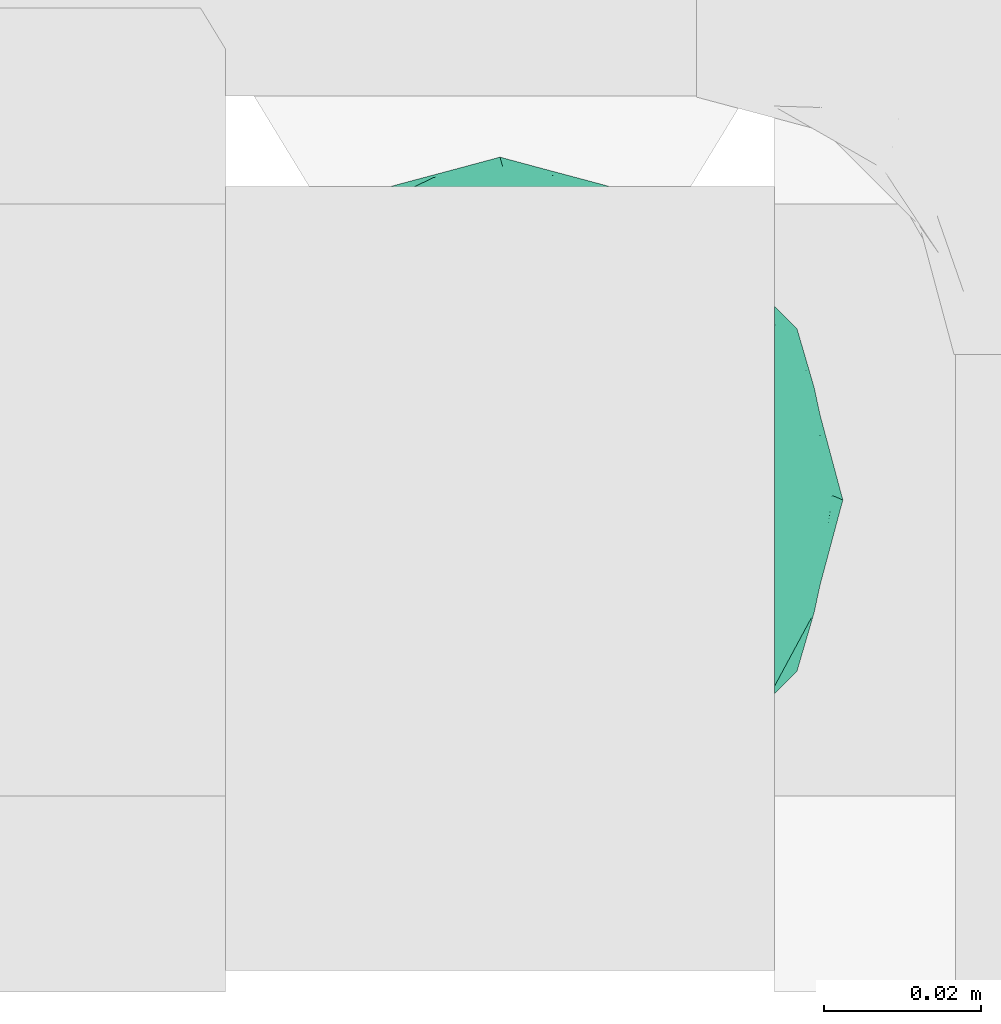
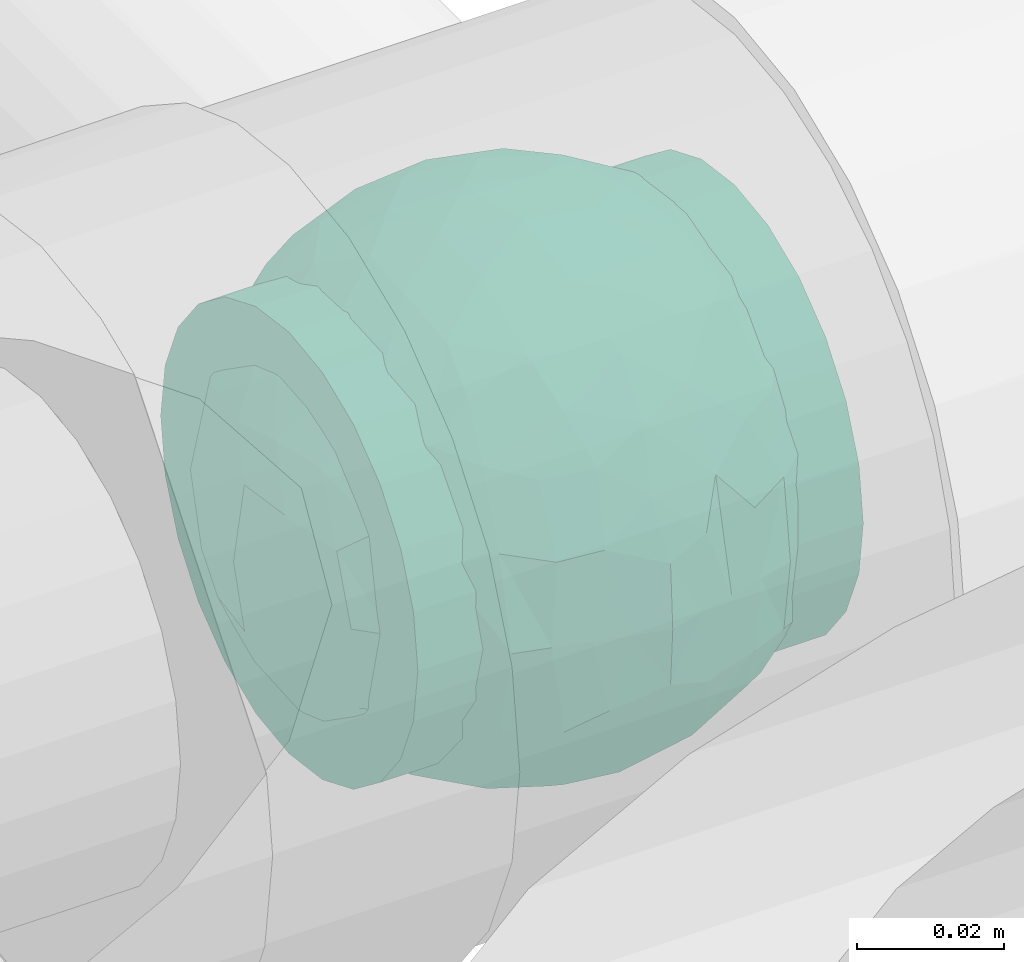
# One storey, part 692 of 827: 1 flow fitting.
"""IFC2X3 building model written with IfcOpenShell, lengths in millimetres."""

import ifcopenshell
import ifcopenshell.guid

model = None  # the IFC model being written
_history = None  # IfcOwnerHistory: only IFC2X3 demands one
_inside = {}  # id of a spatial element -> (the spatial element, [elements in it])
_under = {}  # id of a project, library or spatial element -> (it, [spatial elements below it])
_declared = {}  # id of a project -> (the project, [libraries it declares])
_typed = {}  # id of a type object -> (the type object, [elements of that type])
_made_of = {}  # id of a material, layer set ... -> (it, [elements and type objects made of it])


def new_model(schema):
    """Start an empty IFC model of exactly this schema.

    Asked for "IFC4X3", IfcOpenShell would pick the latest addendum, in which some entities
    have other attributes; the version numbers below select the first issue.
    IFC2X3 requires an IfcOwnerHistory on every rooted entity: one is made here for all.
    """
    global model, _history
    if schema == "IFC4X3":
        model = ifcopenshell.file(schema_version=(4, 3, 0, 0))
    else:
        model = ifcopenshell.file(schema=schema)
    _inside.clear()
    _under.clear()
    _declared.clear()
    _typed.clear()
    _made_of.clear()
    _history = None
    if model.schema == "IFC2X3":
        org = make("IfcOrganization", Name="unknown")
        user = make(
            "IfcPersonAndOrganization",
            ThePerson=make("IfcPerson", FamilyName="unknown"),
            TheOrganization=org,
        )
        app = make(
            "IfcApplication",
            ApplicationDeveloper=org,
            Version="unknown",
            ApplicationFullName="unknown",
            ApplicationIdentifier="unknown",
        )
        _history = make(
            "IfcOwnerHistory",
            OwningUser=user,
            OwningApplication=app,
            ChangeAction="ADDED",
            CreationDate=0,
        )
    return model


def make(cls, **values):
    """One entity of the class cls with the attributes given. An attribute that is None is left unset."""
    return model.create_entity(
        cls, **{name: value for name, value in values.items() if value is not None}
    )


def entity(cls, *values):
    """Any entity or typed value of the class cls, its attributes in the order of the schema. None: left unset."""
    e = model.create_entity(cls)
    for i, value in enumerate(values):
        if value is not None:
            e[i] = value
    return e


def rooted(cls, **values):
    """An entity with a GlobalId (a new one), such as an element, a storey or a relation."""
    return make(cls, GlobalId=ifcopenshell.guid.new(), OwnerHistory=_history, **values)


def si_unit(unit_type, name, prefix=None):
    """IfcSIUnit, for example si_unit("LENGTHUNIT", "METRE", prefix="MILLI")."""
    return make("IfcSIUnit", UnitType=unit_type, Prefix=prefix, Name=name)


def converted_unit(unit_type, name, factor, base, dimensions=None, offset=None):
    """IfcConversionBasedUnit, such as the inch: factor (a typed value) times the base unit."""
    return make(
        "IfcConversionBasedUnit"
        if offset is None
        else "IfcConversionBasedUnitWithOffset",
        ConversionOffset=offset,
        Dimensions=None
        if dimensions is None
        else entity("IfcDimensionalExponents", *dimensions),
        UnitType=unit_type,
        Name=name,
        ConversionFactor=make(
            "IfcMeasureWithUnit", ValueComponent=factor, UnitComponent=base
        ),
    )


def derived_unit(unit_type, elements):
    """IfcDerivedUnit: a product of units, each with its exponent."""
    return make(
        "IfcDerivedUnit",
        Elements=[
            make("IfcDerivedUnitElement", Unit=unit, Exponent=power)
            for unit, power in elements
        ],
        UnitType=unit_type,
    )


def assignment(units):
    """IfcUnitAssignment: the units of a project."""
    return None if units is None else make("IfcUnitAssignment", Units=units)


def point(xyz):
    """IfcCartesianPoint."""
    return None if xyz is None else make("IfcCartesianPoint", Coordinates=xyz)


def direction(xyz):
    """IfcDirection."""
    return None if xyz is None else make("IfcDirection", DirectionRatios=xyz)


def frame(location, z_axis=None, x_axis=None):
    """IfcAxis2Placement3D, a coordinate frame: its origin and axes. An axis left out is left unset."""
    return make(
        "IfcAxis2Placement3D",
        Location=point(location),
        Axis=direction(z_axis),
        RefDirection=direction(x_axis),
    )


def origin():
    """The frame at (0, 0, 0) with its axes left unset."""
    return frame((0.0, 0.0, 0.0))


def place(relative_to, where):
    """IfcLocalPlacement: puts the frame where relative to a parent placement (None: the world)."""
    return make(
        "IfcLocalPlacement", PlacementRelTo=relative_to, RelativePlacement=where
    )


def context(
    kind, dimensions, precision=None, world=None, true_north=None, identifier=None
):
    """IfcGeometricRepresentationContext, for example the 3D "Model" context."""
    return make(
        "IfcGeometricRepresentationContext",
        ContextIdentifier=identifier,
        ContextType=kind,
        CoordinateSpaceDimension=dimensions,
        Precision=precision,
        WorldCoordinateSystem=world,
        TrueNorth=true_north,
    )


def subcontext(parent, identifier, kind, view, scale=None):
    """IfcGeometricRepresentationSubContext, for example "Body" below "Model"."""
    return make(
        "IfcGeometricRepresentationSubContext",
        ContextIdentifier=identifier,
        ContextType=kind,
        ParentContext=parent,
        TargetScale=scale,
        TargetView=view,
    )


def project(units=None, contexts=None):
    """IfcProject with its units and contexts."""
    return rooted(
        "IfcProject",
        Name="project",
        RepresentationContexts=contexts,
        UnitsInContext=assignment(units),
    )


def spatial(cls, under=None, at=None, **own):
    """A site, building, storey or space (cls), placed at a placement, below another one or the project."""
    s = rooted(cls, ObjectPlacement=at, **own)
    if under is not None:
        _under.setdefault(under.id(), (under, []))[1].append(s)
    return s


def faces_of(points, faces, orient=None, outer=None):
    """IfcFace entities. A face is a list of loops; a loop is a list of indices into points, from 0.

    orient and outer hold one flag for each loop. By default every Orientation is true, the
    first loop of a face is its IfcFaceOuterBound and the others are IfcFaceBound.
    """
    made = []
    for i, loops in enumerate(faces):
        bounds = []
        for j, loop in enumerate(loops):
            is_outer = j == 0 if outer is None else outer[i][j]
            bounds.append(
                make(
                    "IfcFaceOuterBound" if is_outer else "IfcFaceBound",
                    Bound=make("IfcPolyLoop", Polygon=[points[k] for k in loop]),
                    Orientation=True if orient is None else orient[i][j],
                )
            )
        made.append(make("IfcFace", Bounds=bounds))
    return made


def faceted_brep(points, faces, orient=None, outer=None, voids=None):
    """IfcFacetedBrep: a solid bounded by flat faces; with voids (closed shells), ...WithVoids."""
    shared = [point(p) for p in points]
    hull = make("IfcClosedShell", CfsFaces=faces_of(shared, faces, orient, outer))
    if voids is None:
        return make("IfcFacetedBrep", Outer=hull)
    return make(
        "IfcFacetedBrepWithVoids",
        Outer=hull,
        Voids=[
            make(cls, CfsFaces=faces_of(shared, fs, o, b)) for cls, fs, o, b in voids
        ],
    )


def shape(context_of_items, identifier, shape_type, items):
    """IfcShapeRepresentation: the items that make up one representation, for example the "Body"."""
    return make(
        "IfcShapeRepresentation",
        ContextOfItems=context_of_items,
        RepresentationIdentifier=identifier,
        RepresentationType=shape_type,
        Items=items,
    )


def source(mapping_origin, context_of_items, identifier, shape_type, items):
    """IfcRepresentationMap: a shape defined once, which mapped items show again and again."""
    return make(
        "IfcRepresentationMap",
        MappingOrigin=mapping_origin,
        MappedRepresentation=shape(context_of_items, identifier, shape_type, items),
    )


def transform(
    local_origin,
    x_axis=None,
    y_axis=None,
    z_axis=None,
    scale=None,
    scale2=None,
    scale3=None,
    uniform=True,
):
    """IfcCartesianTransformationOperator3D, or its non-uniform kind. x_axis, y_axis, z_axis: its Axis1, 2, 3."""
    if uniform:
        return make(
            "IfcCartesianTransformationOperator3D",
            Axis1=direction(x_axis),
            Axis2=direction(y_axis),
            LocalOrigin=point(local_origin),
            Scale=scale,
            Axis3=direction(z_axis),
        )
    return make(
        "IfcCartesianTransformationOperator3DnonUniform",
        Axis1=direction(x_axis),
        Axis2=direction(y_axis),
        LocalOrigin=point(local_origin),
        Scale=scale,
        Axis3=direction(z_axis),
        Scale2=scale2,
        Scale3=scale3,
    )


def mapped(mapping_source, mapping_target):
    """IfcMappedItem: shows the shape of a source again, moved by a transform."""
    return make(
        "IfcMappedItem", MappingSource=mapping_source, MappingTarget=mapping_target
    )


def material(Name=None, Category=None):
    """IfcMaterial."""
    return make("IfcMaterial", Name=Name, Category=Category)


def material_list(materials):
    """IfcMaterialList."""
    return make("IfcMaterialList", Materials=materials)


def made_of(thing, what):
    """Note that an element or type object is made of a material, layer set ...; save() writes the relation."""
    if what is not None:
        _made_of.setdefault(what.id(), (what, []))[1].append(thing)
    return thing


def type_object(cls, material=None, **own):
    """A type object (cls), such as IfcWallType, which elements share."""
    return made_of(rooted(cls, **own), material)


def type_shapes(of_type, sources):
    """Give a type object the sources (RepresentationMaps) that its elements show as mapped items."""
    of_type.RepresentationMaps = sources


def element(
    cls,
    number,
    at=None,
    inside=None,
    cuts=None,
    type_object=None,
    material=None,
    context=None,
    identifier="Body",
    shape_type=None,
    held_by="IfcProductDefinitionShape",
    body=None,
    shapes=None,
    **own,
):
    """One element of the class cls, such as IfcWall. Its Tag is "e" and its number.

    at: its placement. inside: the storey or other place that contains it. cuts: it is an
    opening in that element (IfcRelVoidsElement). A single representation is given by context,
    identifier, shape_type and body (its items); several are given by shapes. held_by: the class
    of the entity that holds the representations. save() writes the other relations.
    """
    e = rooted(cls, Tag="e%d" % number, ObjectPlacement=at, **own)
    if body is not None:
        shapes = [shape(context, identifier, shape_type, body)]
    if shapes is not None:
        e.Representation = make(held_by, Representations=shapes)
    if inside is not None:
        _inside.setdefault(inside.id(), (inside, []))[1].append(e)
    if cuts is not None:
        rooted(
            "IfcRelVoidsElement", RelatingBuildingElement=cuts, RelatedOpeningElement=e
        )
    if type_object is not None:
        _typed.setdefault(type_object.id(), (type_object, []))[1].append(e)
    return made_of(e, material)


def aggregate(whole, parts):
    """IfcRelAggregates: a whole, such as a stair, and the parts it consists of."""
    return rooted("IfcRelAggregates", RelatingObject=whole, RelatedObjects=parts)


def save(model, path):
    """Write the relations noted so far, then the file.

    IfcRelAggregates (storeys below a building ...), IfcRelContainedInSpatialStructure (elements
    in a storey), IfcRelDefinesByType, IfcRelAssociatesMaterial and IfcRelDeclares: one each for
    every whole, place, type object, material and project.
    """
    for whole, parts in _under.values():
        aggregate(whole, parts)
    for where, things in _inside.values():
        rooted(
            "IfcRelContainedInSpatialStructure",
            RelatedElements=things,
            RelatingStructure=where,
        )
    for kind, things in _typed.values():
        rooted("IfcRelDefinesByType", RelatedObjects=things, RelatingType=kind)
    for what, things in _made_of.values():
        rooted("IfcRelAssociatesMaterial", RelatedObjects=things, RelatingMaterial=what)
    for by, libraries in _declared.values():
        rooted("IfcRelDeclares", RelatingContext=by, RelatedDefinitions=libraries)
    model.write(path)


model = new_model("IFC2X3")

# Units and contexts
model_context = context("Model", 3, precision=0.01, world=origin(), true_north=direction((6.12303176911189e-17, 1.0)))
body_context = subcontext(model_context, "Body", "Model", "MODEL_VIEW")
ifc_project = project(units=[si_unit("LENGTHUNIT", "METRE", prefix="MILLI"), si_unit("AREAUNIT", "SQUARE_METRE"), si_unit("VOLUMEUNIT", "CUBIC_METRE"), converted_unit("PLANEANGLEUNIT", "DEGREE", entity("IfcRatioMeasure", 0.0174532925199433), si_unit("PLANEANGLEUNIT", "RADIAN"), dimensions=[0, 0, 0, 0, 0, 0, 0]), si_unit("MASSUNIT", "GRAM", prefix="KILO"), derived_unit("MASSDENSITYUNIT", [(si_unit("MASSUNIT", "GRAM", prefix="KILO"), 1), (si_unit("LENGTHUNIT", "METRE"), -3)]), derived_unit("MOMENTOFINERTIAUNIT", [(si_unit("LENGTHUNIT", "METRE"), 4)]), si_unit("TIMEUNIT", "SECOND"), si_unit("FREQUENCYUNIT", "HERTZ"), si_unit("THERMODYNAMICTEMPERATUREUNIT", "DEGREE_CELSIUS"), derived_unit("THERMALTRANSMITTANCEUNIT", [(si_unit("MASSUNIT", "GRAM", prefix="KILO"), 1), (si_unit("THERMODYNAMICTEMPERATUREUNIT", "KELVIN"), -1), (si_unit("TIMEUNIT", "SECOND"), -3)]), derived_unit("VOLUMETRICFLOWRATEUNIT", [(si_unit("LENGTHUNIT", "METRE"), 3), (si_unit("TIMEUNIT", "SECOND"), -1)]), derived_unit("MASSFLOWRATEUNIT", [(si_unit("MASSUNIT", "GRAM", prefix="KILO"), 1), (si_unit("TIMEUNIT", "SECOND"), -1)]), derived_unit("ROTATIONALFREQUENCYUNIT", [(si_unit("TIMEUNIT", "SECOND"), -1)]), si_unit("ELECTRICCURRENTUNIT", "AMPERE"), si_unit("ELECTRICVOLTAGEUNIT", "VOLT"), si_unit("POWERUNIT", "WATT"), si_unit("FORCEUNIT", "NEWTON", prefix="KILO"), si_unit("ILLUMINANCEUNIT", "LUX"), si_unit("LUMINOUSFLUXUNIT", "LUMEN"), si_unit("LUMINOUSINTENSITYUNIT", "CANDELA"), derived_unit("USERDEFINED", [(si_unit("MASSUNIT", "GRAM", prefix="KILO"), -1), (si_unit("LENGTHUNIT", "METRE"), -2), (si_unit("TIMEUNIT", "SECOND"), 3), (si_unit("LUMINOUSFLUXUNIT", "LUMEN"), 1)]), derived_unit("LINEARVELOCITYUNIT", [(si_unit("LENGTHUNIT", "METRE"), 1), (si_unit("TIMEUNIT", "SECOND"), -1)]), si_unit("PRESSUREUNIT", "PASCAL"), derived_unit("USERDEFINED", [(si_unit("LENGTHUNIT", "METRE"), -2), (si_unit("MASSUNIT", "GRAM", prefix="KILO"), 1), (si_unit("TIMEUNIT", "SECOND"), -2)]), derived_unit("LINEARFORCEUNIT", [(si_unit("MASSUNIT", "GRAM", prefix="KILO"), 1), (si_unit("LENGTHUNIT", "METRE"), 1), (si_unit("TIMEUNIT", "SECOND"), -2), (si_unit("LENGTHUNIT", "METRE"), -1)]), derived_unit("PLANARFORCEUNIT", [(si_unit("MASSUNIT", "GRAM", prefix="KILO"), 1), (si_unit("LENGTHUNIT", "METRE"), 1), (si_unit("TIMEUNIT", "SECOND"), -2), (si_unit("LENGTHUNIT", "METRE"), -2)])], contexts=[model_context])

# Site, building, storey
site_placement = place(None, origin())
site = spatial("IfcSite", under=ifc_project, at=site_placement, CompositionType="ELEMENT")
building_placement = place(site_placement, origin())
building = spatial("IfcBuilding", under=site, at=building_placement, CompositionType="ELEMENT")
storey_placement = place(building_placement, frame((0.0, 0.0, 28200.0)))
storey = spatial("IfcBuildingStorey", under=building, at=storey_placement, Name="08", CompositionType="ELEMENT", Elevation=28200.0)

# Flow fitting
ifc_material_1 = material()
ifc_material_2 = material(Name="ADSK_")
ifc_material_list = material_list([ifc_material_1, ifc_material_2])
pipe_fitting_type = type_object("IfcPipeFittingType", Name="ADSK_1", PredefinedType="NOTDEFINED", material=ifc_material_list)
shared_shape = source(origin(), body_context, "Body", "Brep", [
    faceted_brep([(-35.0, 9.06, -33.81), (-35.0, 0.0, -35.0), (-35.0, -9.06, -33.81), (-35.0, -17.5, -30.31), (-35.0, -24.75, -24.75), (-35.0, -30.31, -17.5), (-35.0, -33.81, -9.06), (-35.0, -34.4, -4.53), (-35.0, -35.0, 0.0), (-35.0, -34.4, 4.53), (-35.0, -33.81, 9.06), (-35.0, -30.31, 17.5), (-35.0, -24.75, 24.75), (-35.0, -17.5, 30.31), (-35.0, -9.06, 33.81), (-35.0, 0.0, 35.0), (-35.0, 9.06, 33.81), (-35.0, 17.5, 30.31), (-35.0, 24.75, 24.75), (-35.0, 30.31, 17.5), (-35.0, 33.81, 9.06), (-35.0, 35.0, 0.0), (-35.0, 33.81, -9.06), (-35.0, 30.31, -17.5), (-35.0, 24.75, -24.75), (-35.0, 17.5, -30.31), (35.0, 33.81, -9.06), (35.0, 35.0, 0.0), (35.0, 33.81, 9.06), (35.0, 30.31, 17.5), (35.0, 24.75, 24.75), (35.0, 17.5, 30.31), (35.0, 9.06, 33.81), (35.0, 0.0, 35.0), (35.0, -9.06, 33.81), (35.0, -17.5, 30.31), (35.0, -24.75, 24.75), (35.0, -30.31, 17.5), (35.0, -33.81, 9.06), (35.0, -34.4, 4.53), (35.0, -35.0, 0.0), (35.0, -34.4, -4.53), (35.0, -33.81, -9.06), (35.0, -30.31, -17.5), (35.0, -24.75, -24.75), (35.0, -17.5, -30.31), (35.0, -9.06, -33.81), (35.0, 0.0, -35.0), (35.0, 9.06, -33.81), (35.0, 17.5, -30.31), (35.0, 24.75, -24.75), (35.0, 30.31, -17.5), (12.5, -35.0, 0.0), (11.74, -34.73, 4.3), (9.57, -34.06, 8.04), (2.19, -32.76, 12.31), (6.27, -33.29, 10.81), (-9.57, -34.06, 8.04), (-11.74, -34.73, 4.3), (-12.5, -35.0, 0.0), (-6.27, -33.29, 10.81), (-2.19, -32.76, 12.31), (-11.74, -34.73, -4.3), (9.57, -34.06, -8.04), (11.74, -34.73, -4.3), (6.27, -33.29, -10.81), (2.19, -32.76, -12.31), (-2.19, -32.76, -12.31), (-6.27, -33.29, -10.81), (-9.57, -34.06, -8.04), (0.0, -40.0, -12.5), (3.24, -40.0, -12.07), (6.25, -40.0, -10.83), (8.84, -40.0, -8.84), (10.83, -40.0, -6.25), (12.07, -40.0, -3.24), (12.5, -40.0, 0.0), (12.07, -40.0, 3.24), (10.83, -40.0, 6.25), (8.84, -40.0, 8.84), (6.25, -40.0, 10.83), (3.24, -40.0, 12.07), (0.0, -40.0, 12.5), (-3.24, -40.0, 12.07), (-6.25, -40.0, 10.83), (-8.84, -40.0, 8.84), (-10.83, -40.0, 6.25), (-12.07, -40.0, 3.24), (-12.5, -40.0, 0.0), (-12.07, -40.0, -3.24), (-10.83, -40.0, -6.25), (-8.84, -40.0, -8.84), (-6.25, -40.0, -10.83), (-3.24, -40.0, -12.07)], [[[0, 1, 2, 3, 4, 5, 6, 7, 8, 9, 10, 11, 12, 13, 14, 15, 16, 17, 18, 19, 20, 21, 22, 23, 24, 25]], [[26, 27, 28, 29, 30, 31, 32, 33, 34, 35, 36, 37, 38, 39, 40, 41, 42, 43, 44, 45, 46, 47, 48, 49, 50, 51]], [[52, 40, 53]], [[54, 53, 39]], [[39, 38, 54]], [[55, 37, 11]], [[38, 55, 56]], [[55, 38, 37]], [[38, 56, 54]], [[37, 36, 12, 11]], [[57, 9, 58]], [[8, 58, 9]], [[8, 59, 58]], [[57, 10, 9]], [[60, 61, 10]], [[61, 11, 10]], [[61, 55, 11]], [[60, 10, 57]], [[53, 40, 39]], [[36, 35, 13, 12]], [[15, 14, 34, 33]], [[14, 13, 35, 34]], [[16, 15, 33, 32]], [[29, 28, 20, 19]], [[18, 17, 31, 30]], [[19, 18, 30, 29]], [[32, 31, 17, 16]], [[21, 20, 28, 27]], [[21, 27, 26, 22]], [[22, 26, 51, 23]], [[24, 23, 51, 50]], [[2, 1, 47, 46]], [[0, 25, 49, 48]], [[47, 1, 0, 48]], [[49, 25, 24, 50]], [[45, 3, 2, 46]], [[62, 8, 7]], [[45, 44, 4, 3]], [[5, 4, 44, 43]], [[63, 41, 64]], [[42, 65, 66]], [[66, 43, 42]], [[5, 43, 66]], [[41, 40, 64]], [[63, 42, 41]], [[52, 64, 40]], [[42, 63, 65]], [[5, 67, 6]], [[67, 68, 6]], [[5, 66, 67]], [[62, 7, 69]], [[7, 6, 69]], [[8, 62, 59]], [[69, 6, 68]], [[70, 71, 72, 73, 74, 75, 76, 77, 78, 79, 80, 81, 82, 83, 84, 85, 86, 87, 88, 89, 90, 91, 92, 93]], [[59, 88, 87]], [[58, 86, 85]], [[87, 86, 59]], [[85, 84, 58]], [[59, 86, 58]], [[57, 58, 83]], [[61, 60, 56]], [[57, 54, 60]], [[83, 82, 57]], [[84, 83, 58]], [[54, 82, 81]], [[80, 53, 81]], [[53, 79, 78]], [[80, 79, 53]], [[52, 78, 77]], [[56, 55, 61]], [[54, 56, 60]], [[78, 52, 53]], [[53, 54, 81]], [[52, 77, 76]], [[57, 82, 54]], [[76, 75, 52]], [[73, 72, 64]], [[74, 73, 64]], [[75, 74, 52]], [[52, 74, 64]], [[63, 64, 71]], [[66, 65, 67]], [[63, 68, 65]], [[71, 70, 63]], [[72, 71, 64]], [[93, 92, 62]], [[70, 93, 69]], [[90, 89, 59]], [[91, 90, 62]], [[92, 91, 62]], [[68, 67, 65]], [[69, 68, 63]], [[90, 59, 62]], [[62, 69, 93]], [[59, 89, 88]], [[63, 70, 69]]]),
    faceted_brep([(40.99, -9.07, -12.32), (38.16, -18.39, -10.93), (36.84, -12.08, -20.28), (-10.94, -40.82, 0.0), (-15.58, -39.11, -11.91), (-9.92, -38.23, -18.83), (-21.96, -6.8, -37.22), (-28.12, 0.0, -33.51), (-18.49, 2.46, -39.57), (7.18, -35.67, -24.29), (15.31, -38.73, -13.42), (8.77, -40.44, -14.19), (42.03, 0.03, -12.13), (40.09, 14.36, -10.04), (40.82, 10.94, 0.0), (23.53, 13.3, -34.4), (12.46, 12.13, -40.15), (17.01, 22.71, -33.3), (33.97, -22.81, -15.49), (33.89, -25.88, 0.0), (-17.56, -33.17, -22.48), (-9.73, -30.72, -29.59), (32.82, 10.98, -26.77), (35.78, 20.39, -14.77), (39.41, 6.34, -17.91), (-6.73, 41.38, -12.52), (-10.94, 40.82, 0.0), (-5.47, 42.28, 0.0), (-39.41, -6.34, -17.91), (-34.66, -3.23, -26.5), (-35.7, -17.2, -18.54), (-40.84, 8.27, -13.33), (-40.82, 10.94, 0.0), (-39.08, 16.52, -10.68), (26.2, -22.53, -26.83), (19.73, -22.3, -32.05), (18.8, -14.77, -36.64), (-40.09, -14.36, -10.04), (-42.42, 0.57, -10.68), (-38.6, 2.92, -20.39), (-33.71, 5.81, -27.28), (-35.11, 22.36, -13.46), (-36.84, 12.08, -20.28), (-7.82, 5.75, -42.66), (-4.31, 16.52, -40.28), (2.55, 8.59, -42.82), (-28.09, 28.94, -16.95), (-22.22, 29.25, -23.76), (-22.19, 21.47, -31.0), (-15.79, 13.61, -38.47), (-25.69, 11.2, -33.6), (-34.44, -24.53, -11.23), (-28.84, -30.19, -13.07), (-29.88, -29.88, 0.0), (-30.32, -11.15, -29.5), (-30.71, 19.03, -24.67), (-29.88, 29.88, 0.0), (-21.87, 37.89, 0.0), (-12.26, 23.64, -34.71), (-24.05, -29.02, -22.21), (-22.18, -35.56, -12.55), (-15.83, -24.35, -32.72), (5.66, 19.83, -38.58), (10.82, 1.29, -42.37), (19.64, -4.55, -38.83), (10.45, -9.76, -41.35), (5.47, 42.28, 0.0), (10.94, 40.82, 0.0), (8.45, 41.16, -12.17), (21.88, 37.89, 0.0), (28.41, 30.93, -12.26), (22.11, 34.85, -14.53), (27.19, -11.68, -32.22), (-10.91, -4.19, -42.16), (-0.38, -15.53, -40.9), (-15.09, -13.39, -38.82), (38.72, -2.98, -20.15), (33.54, -5.5, -27.55), (35.26, 2.9, -25.74), (0.73, -39.14, -19.53), (-37.89, 21.87, 0.0), (-33.89, 25.88, 0.0), (14.01, 38.49, -15.38), (15.74, 32.52, -24.68), (5.47, -42.28, 0.0), (-0.33, -42.57, -10.07), (8.2, 28.42, -32.24), (7.65, 35.47, -24.45), (-22.26, 35.43, -12.78), (-16.78, 34.37, -21.23), (-1.21, 33.73, -27.84), (0.73, 39.14, -19.53), (16.41, 39.35, 0.0), (-6.64, -41.44, -12.35), (10.46, -22.3, -36.16), (-1.67, -26.4, -34.84), (-1.24, -33.73, -27.84), (16.41, -39.35, 0.0), (22.1, -34.75, -14.77), (21.88, -37.89, 0.0), (-16.41, 39.35, 0.0), (-15.58, 39.13, -11.84), (-8.82, 37.78, -20.23), (-9.77, 32.04, -28.15), (-23.41, -16.43, -33.11), (0.25, -3.35, -43.62), (39.35, -16.41, 0.0), (28.12, 0.0, -33.51), (29.88, -29.88, 0.0), (28.41, -30.93, -12.26), (32.42, -13.09, -26.29), (-1.67, 26.4, -34.84), (22.5, 28.09, -24.87), (28.62, 22.02, -24.7), (19.21, 5.23, -38.96), (29.88, 29.88, 0.0), (33.89, 25.88, 0.0), (37.89, 21.87, 0.0), (-0.33, 42.57, -10.07), (0.0, 43.75, 0.0), (-8.6, -19.79, -38.06), (9.0, -29.66, -30.88), (15.05, -33.47, -23.82), (21.12, -28.8, -25.27), (-28.7, -22.0, -24.62), (-33.89, -25.88, 0.0), (-43.75, 0.0, 0.0), (-40.82, -10.94, 0.0), (-37.89, -21.88, 0.0), (0.0, -43.75, 0.0), (-5.47, -42.28, 0.0), (-21.87, -37.89, 0.0), (-16.41, -39.35, 0.0), (10.94, -40.82, 0.0), (40.82, -10.94, 0.0), (39.35, 16.41, 0.0), (43.75, 0.0, 0.0), (37.89, -21.88, 0.0), (-35.11, -22.36, 13.46), (-36.84, -12.08, 20.28), (-39.08, -16.52, 10.68), (-15.58, 39.11, 11.91), (-9.92, 38.23, 18.83), (-21.96, 6.8, 37.22), (-28.12, 0.0, 33.51), (-18.49, -2.46, 39.57), (-34.66, 3.23, 26.5), (-38.6, -2.92, 20.39), (-33.71, -5.81, 27.28), (-40.09, 14.36, 10.04), (-42.42, -0.57, 10.68), (-39.41, 6.34, 17.91), (-34.44, 24.53, 11.23), (-28.84, 30.19, 13.07), (33.97, 22.81, 15.49), (38.16, 18.39, 10.93), (-17.56, 33.17, 22.48), (-9.73, 30.72, 29.59), (-35.7, 17.2, 18.54), (-6.73, -41.38, 12.52), (39.41, -6.34, 17.91), (32.82, -10.98, 26.77), (35.78, -20.39, 14.77), (-40.84, -8.27, 13.33), (26.2, 22.53, 26.83), (19.73, 22.3, 32.05), (18.8, 14.77, 36.64), (42.03, -0.03, 12.13), (40.09, -14.36, 10.04), (7.18, 35.67, 24.29), (15.31, 38.73, 13.42), (8.77, 40.44, 14.19), (40.99, 9.07, 12.32), (36.84, 12.08, 20.28), (-7.82, -5.75, 42.66), (-4.31, -16.52, 40.28), (2.55, -8.59, 42.82), (-28.09, -28.94, 16.95), (-22.22, -29.25, 23.76), (-22.19, -21.47, 31.0), (-15.79, -13.61, 38.47), (-25.69, -11.2, 33.6), (12.46, -12.13, 40.15), (17.01, -22.71, 33.3), (23.53, -13.3, 34.4), (-30.32, 11.15, 29.5), (-30.71, -19.03, 24.67), (-12.26, -23.64, 34.71), (-24.05, 29.02, 22.21), (-22.18, 35.56, 12.55), (-15.83, 24.35, 32.72), (5.66, -19.83, 38.58), (10.82, -1.29, 42.37), (19.64, 4.55, 38.83), (10.45, 9.76, 41.35), (8.45, -41.16, 12.17), (28.41, -30.93, 12.26), (22.11, -34.85, 14.53), (27.19, 11.68, 32.22), (-10.91, 4.19, 42.16), (-0.38, 15.53, 40.9), (-15.09, 13.39, 38.82), (38.72, 2.98, 20.15), (33.54, 5.5, 27.55), (35.26, -2.9, 25.74), (0.73, 39.14, 19.53), (14.01, -38.49, 15.38), (15.74, -32.52, 24.68), (-0.33, 42.57, 10.07), (8.2, -28.42, 32.24), (7.65, -35.47, 24.45), (-22.26, -35.43, 12.78), (-16.78, -34.37, 21.23), (-1.21, -33.73, 27.84), (0.73, -39.14, 19.53), (-6.64, 41.44, 12.35), (10.46, 22.3, 36.16), (-1.67, 26.4, 34.84), (-1.24, 33.73, 27.84), (22.1, 34.75, 14.77), (-15.58, -39.13, 11.84), (-8.82, -37.78, 20.23), (-9.77, -32.04, 28.14), (-23.41, 16.43, 33.11), (0.25, 3.35, 43.62), (28.12, 0.0, 33.51), (28.41, 30.93, 12.26), (32.42, 13.09, 26.29), (-1.67, -26.4, 34.84), (22.5, -28.09, 24.87), (28.62, -22.02, 24.7), (19.21, -5.23, 38.96), (-0.33, -42.57, 10.07), (-8.6, 19.79, 38.06), (9.0, 29.66, 30.88), (15.05, 33.47, 23.82), (21.12, 28.8, 25.27), (-28.7, 22.0, 24.62)], [[[0, 1, 2]], [[3, 4, 5]], [[6, 7, 8]], [[9, 10, 11]], [[12, 13, 14]], [[15, 16, 17]], [[18, 1, 19]], [[20, 21, 5]], [[22, 23, 24]], [[25, 26, 27]], [[28, 29, 30]], [[31, 32, 33]], [[34, 35, 36]], [[37, 38, 28]], [[29, 39, 40]], [[33, 41, 42]], [[43, 44, 45]], [[46, 47, 48]], [[49, 8, 50]], [[51, 52, 53]], [[7, 6, 54]], [[55, 50, 40]], [[46, 56, 57]], [[49, 58, 44]], [[46, 55, 41]], [[52, 59, 60]], [[49, 44, 43]], [[59, 61, 20]], [[62, 16, 45]], [[63, 64, 65]], [[66, 67, 68]], [[69, 70, 71]], [[72, 36, 64]], [[73, 74, 75]], [[76, 77, 78]], [[9, 11, 79]], [[41, 80, 81, 56]], [[82, 71, 83]], [[11, 84, 85]], [[86, 87, 83]], [[88, 89, 47]], [[87, 82, 83]], [[87, 90, 91]], [[71, 82, 92]], [[17, 16, 62]], [[79, 85, 93]], [[74, 94, 95]], [[9, 79, 96]], [[97, 98, 99]], [[100, 26, 101]], [[55, 46, 48]], [[90, 102, 91]], [[102, 103, 89]], [[104, 61, 59]], [[20, 61, 21]], [[8, 7, 50]], [[105, 43, 45]], [[0, 106, 1]], [[107, 15, 22]], [[108, 109, 18]], [[110, 72, 77]], [[50, 55, 48]], [[109, 99, 98]], [[41, 55, 42]], [[49, 50, 48]], [[50, 7, 40]], [[58, 49, 48]], [[49, 43, 8]], [[73, 8, 43]], [[8, 73, 6]], [[58, 48, 47]], [[58, 111, 44]], [[62, 44, 111]], [[44, 62, 45]], [[39, 38, 31]], [[46, 41, 56]], [[111, 86, 62]], [[62, 86, 17]], [[112, 83, 71]], [[15, 17, 113]], [[90, 87, 86]], [[17, 86, 83]], [[22, 15, 113]], [[107, 64, 114]], [[23, 113, 70]], [[24, 76, 78]], [[113, 23, 22]], [[23, 115, 116, 117]], [[13, 12, 24]], [[90, 86, 111]], [[87, 91, 68]], [[68, 118, 66]], [[69, 71, 92]], [[82, 67, 92]], [[70, 69, 115]], [[83, 112, 17]], [[23, 70, 115]], [[112, 70, 113]], [[103, 111, 58]], [[82, 68, 67]], [[90, 103, 102]], [[101, 102, 89]], [[27, 119, 118]], [[27, 118, 25]], [[16, 63, 45]], [[45, 63, 105]], [[74, 105, 65]], [[73, 75, 6]], [[16, 15, 114]], [[105, 63, 65]], [[94, 74, 65]], [[21, 120, 95]], [[65, 64, 36]], [[121, 122, 9]], [[114, 64, 63]], [[72, 64, 107]], [[72, 107, 77]], [[35, 34, 123]], [[34, 36, 72]], [[94, 65, 36]], [[66, 118, 119]], [[25, 91, 102]], [[87, 68, 82]], [[118, 68, 91]], [[70, 112, 71]], [[113, 17, 112]], [[43, 105, 73]], [[74, 73, 105]], [[16, 114, 63]], [[107, 114, 15]], [[91, 25, 118]], [[25, 102, 101]], [[75, 104, 6]], [[6, 104, 54]], [[30, 54, 124]], [[29, 7, 54]], [[53, 125, 51]], [[40, 42, 55]], [[104, 75, 61]], [[37, 30, 51]], [[54, 104, 124]], [[120, 61, 75]], [[61, 120, 21]], [[111, 103, 90]], [[58, 89, 103]], [[30, 29, 54]], [[39, 29, 28]], [[125, 37, 51]], [[40, 39, 42]], [[38, 39, 28]], [[41, 33, 80]], [[32, 38, 126]], [[127, 37, 128]], [[127, 126, 38]], [[7, 29, 40]], [[95, 96, 21]], [[21, 96, 5]], [[85, 129, 130]], [[131, 60, 132]], [[94, 121, 95]], [[5, 96, 79]], [[96, 95, 121]], [[5, 93, 3]], [[9, 122, 10]], [[97, 10, 98]], [[129, 85, 84]], [[11, 133, 84]], [[121, 9, 96]], [[121, 94, 35]], [[122, 123, 98]], [[133, 11, 10]], [[99, 109, 108]], [[123, 109, 98]], [[72, 110, 34]], [[34, 18, 109]], [[1, 18, 2]], [[98, 10, 122]], [[97, 133, 10]], [[93, 85, 130]], [[85, 79, 11]], [[3, 93, 130]], [[79, 93, 5]], [[42, 39, 31]], [[32, 80, 33]], [[123, 122, 121]], [[109, 123, 34]], [[121, 35, 123]], [[94, 36, 35]], [[38, 37, 127]], [[30, 37, 28]], [[30, 124, 51]], [[128, 37, 125]], [[52, 51, 124]], [[59, 52, 124]], [[131, 53, 52]], [[59, 124, 104]], [[59, 20, 60]], [[3, 132, 4]], [[60, 20, 4]], [[52, 60, 131]], [[24, 23, 13]], [[19, 108, 18]], [[12, 134, 0]], [[2, 76, 0]], [[0, 76, 12]], [[77, 76, 2]], [[12, 76, 24]], [[77, 2, 110]], [[78, 107, 22]], [[13, 117, 135, 14]], [[134, 12, 136]], [[107, 78, 77]], [[136, 12, 14]], [[24, 78, 22]], [[1, 137, 19]], [[106, 0, 134]], [[106, 137, 1]], [[23, 117, 13]], [[2, 18, 110]], [[34, 110, 18]], [[60, 4, 132]], [[20, 5, 4]], [[32, 31, 38]], [[42, 31, 33]], [[100, 101, 88]], [[58, 47, 89]], [[88, 46, 57]], [[46, 88, 47]], [[100, 88, 57]], [[101, 26, 25]], [[88, 101, 89]], [[75, 74, 120]], [[95, 120, 74]], [[138, 139, 140]], [[26, 141, 142]], [[143, 144, 145]], [[146, 147, 148]], [[149, 150, 151]], [[56, 152, 153]], [[154, 155, 116]], [[156, 157, 142]], [[146, 158, 151]], [[159, 3, 130]], [[160, 161, 162]], [[163, 127, 140]], [[164, 165, 166]], [[167, 168, 134]], [[169, 170, 171]], [[172, 155, 173]], [[174, 175, 176]], [[177, 178, 179]], [[180, 145, 181]], [[182, 183, 184]], [[144, 143, 185]], [[186, 181, 148]], [[177, 53, 131]], [[180, 187, 175]], [[177, 186, 138]], [[153, 188, 189]], [[180, 175, 174]], [[188, 190, 156]], [[191, 182, 176]], [[192, 193, 194]], [[84, 133, 195]], [[99, 196, 197]], [[198, 166, 193]], [[199, 200, 201]], [[202, 203, 204]], [[169, 171, 205]], [[138, 128, 125, 53]], [[206, 197, 207]], [[171, 66, 208]], [[209, 210, 207]], [[211, 212, 178]], [[210, 206, 207]], [[210, 213, 214]], [[197, 206, 97]], [[183, 182, 191]], [[205, 208, 215]], [[200, 216, 217]], [[169, 205, 218]], [[92, 219, 69]], [[132, 3, 220]], [[186, 177, 179]], [[213, 221, 214]], [[221, 222, 212]], [[223, 190, 188]], [[156, 190, 157]], [[145, 144, 181]], [[224, 174, 176]], [[172, 135, 155]], [[225, 184, 161]], [[115, 226, 154]], [[227, 198, 203]], [[181, 186, 179]], [[226, 69, 219]], [[138, 186, 139]], [[180, 181, 179]], [[181, 144, 148]], [[187, 180, 179]], [[180, 174, 145]], [[199, 145, 174]], [[145, 199, 143]], [[187, 179, 178]], [[187, 228, 175]], [[191, 175, 228]], [[175, 191, 176]], [[147, 150, 163]], [[177, 138, 53]], [[228, 209, 191]], [[191, 209, 183]], [[229, 207, 197]], [[184, 183, 230]], [[213, 210, 209]], [[183, 209, 207]], [[161, 184, 230]], [[225, 193, 231]], [[162, 230, 196]], [[160, 202, 204]], [[230, 162, 161]], [[162, 108, 19, 137]], [[168, 167, 160]], [[213, 209, 228]], [[210, 214, 195]], [[195, 232, 84]], [[99, 197, 97]], [[206, 133, 97]], [[196, 99, 108]], [[207, 229, 183]], [[162, 196, 108]], [[229, 196, 230]], [[222, 228, 187]], [[206, 195, 133]], [[213, 222, 221]], [[220, 221, 212]], [[130, 129, 232]], [[130, 232, 159]], [[182, 192, 176]], [[176, 192, 224]], [[200, 224, 194]], [[199, 201, 143]], [[182, 184, 231]], [[224, 192, 194]], [[216, 200, 194]], [[157, 233, 217]], [[194, 193, 166]], [[234, 235, 169]], [[231, 193, 192]], [[198, 193, 225]], [[198, 225, 203]], [[165, 164, 236]], [[164, 166, 198]], [[216, 194, 166]], [[84, 232, 129]], [[159, 214, 221]], [[210, 195, 206]], [[232, 195, 214]], [[196, 229, 197]], [[230, 183, 229]], [[174, 224, 199]], [[200, 199, 224]], [[182, 231, 192]], [[225, 231, 184]], [[214, 159, 232]], [[159, 221, 220]], [[201, 223, 143]], [[143, 223, 185]], [[158, 185, 237]], [[146, 144, 185]], [[56, 81, 152]], [[148, 139, 186]], [[223, 201, 190]], [[149, 158, 152]], [[185, 223, 237]], [[233, 190, 201]], [[190, 233, 157]], [[228, 222, 213]], [[187, 212, 222]], [[158, 146, 185]], [[147, 146, 151]], [[81, 149, 152]], [[148, 147, 139]], [[150, 147, 151]], [[138, 140, 128]], [[127, 150, 126]], [[32, 149, 80]], [[32, 126, 150]], [[144, 146, 148]], [[217, 218, 157]], [[157, 218, 142]], [[208, 119, 27]], [[57, 189, 100]], [[216, 234, 217]], [[142, 218, 205]], [[218, 217, 234]], [[142, 215, 26]], [[169, 235, 170]], [[92, 170, 219]], [[119, 208, 66]], [[171, 67, 66]], [[234, 169, 218]], [[234, 216, 165]], [[235, 236, 219]], [[67, 171, 170]], [[69, 226, 115]], [[236, 226, 219]], [[198, 227, 164]], [[164, 154, 226]], [[155, 154, 173]], [[219, 170, 235]], [[92, 67, 170]], [[215, 208, 27]], [[208, 205, 171]], [[26, 215, 27]], [[205, 215, 142]], [[139, 147, 163]], [[127, 128, 140]], [[236, 235, 234]], [[226, 236, 164]], [[234, 165, 236]], [[216, 166, 165]], [[150, 149, 32]], [[158, 149, 151]], [[158, 237, 152]], [[80, 149, 81]], [[153, 152, 237]], [[188, 153, 237]], [[57, 56, 153]], [[188, 237, 223]], [[188, 156, 189]], [[26, 100, 141]], [[189, 156, 141]], [[153, 189, 57]], [[160, 162, 168]], [[116, 115, 154]], [[167, 14, 172]], [[173, 202, 172]], [[172, 202, 167]], [[203, 202, 173]], [[167, 202, 160]], [[203, 173, 227]], [[204, 225, 161]], [[168, 137, 106, 134]], [[14, 167, 136]], [[225, 204, 203]], [[136, 167, 134]], [[160, 204, 161]], [[155, 117, 116]], [[135, 172, 14]], [[135, 117, 155]], [[162, 137, 168]], [[173, 154, 227]], [[164, 227, 154]], [[189, 141, 100]], [[156, 142, 141]], [[127, 163, 150]], [[139, 163, 140]], [[132, 220, 211]], [[187, 178, 212]], [[211, 177, 131]], [[177, 211, 178]], [[132, 211, 131]], [[220, 3, 159]], [[211, 220, 212]], [[201, 200, 233]], [[217, 233, 200]]]),
])
type_shapes(pipe_fitting_type, [shared_shape])
flow_fitting_placement = place(storey_placement, frame((54339.79, 16072.38, 2700.04), z_axis=(0.0, 0.0, 1.0), x_axis=(-1.0, 0.0, 0.0)))
element("IfcFlowFitting", 1, at=flow_fitting_placement, inside=storey, type_object=pipe_fitting_type, material=ifc_material_list, Name="ADSK_1", ObjectType="ADSK_1", context=body_context, shape_type="MappedRepresentation", body=[
    mapped(shared_shape, transform((0.0, 0.0, 0.0), scale=1.0)),
])

save(model, "model.ifc")
